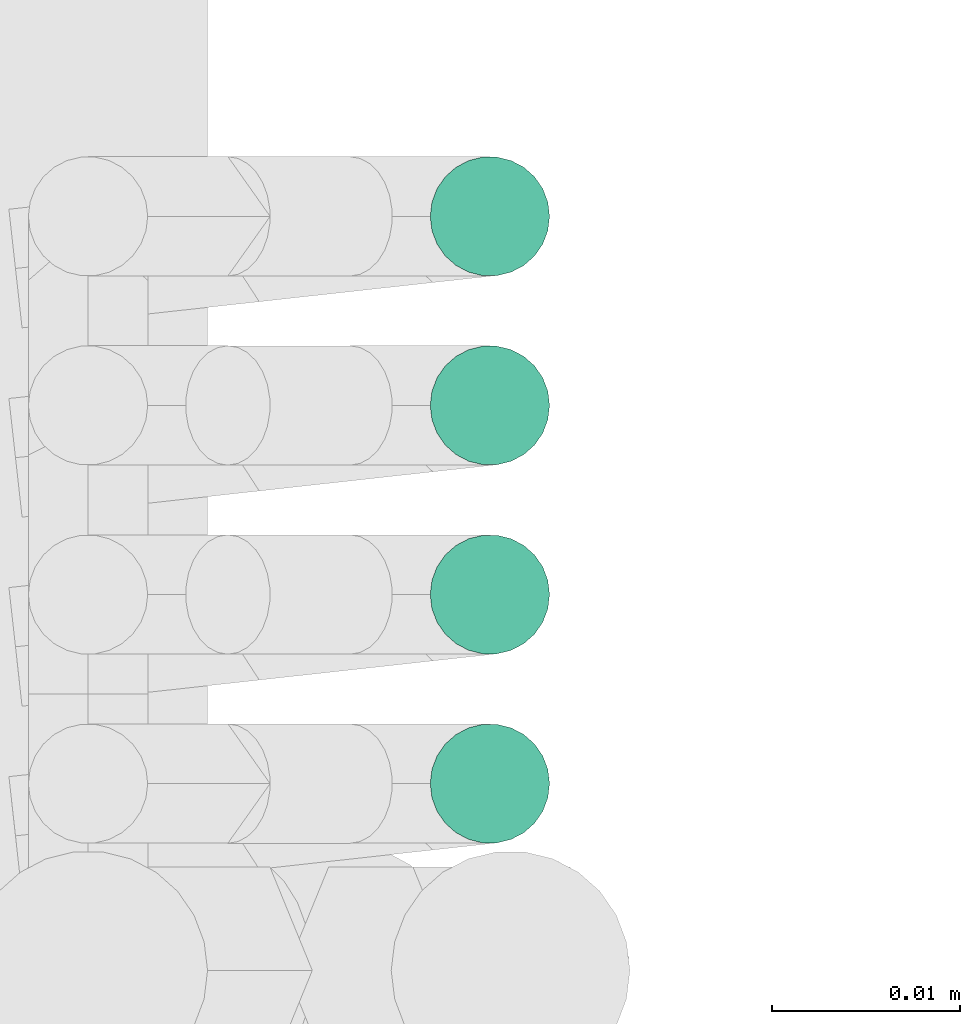
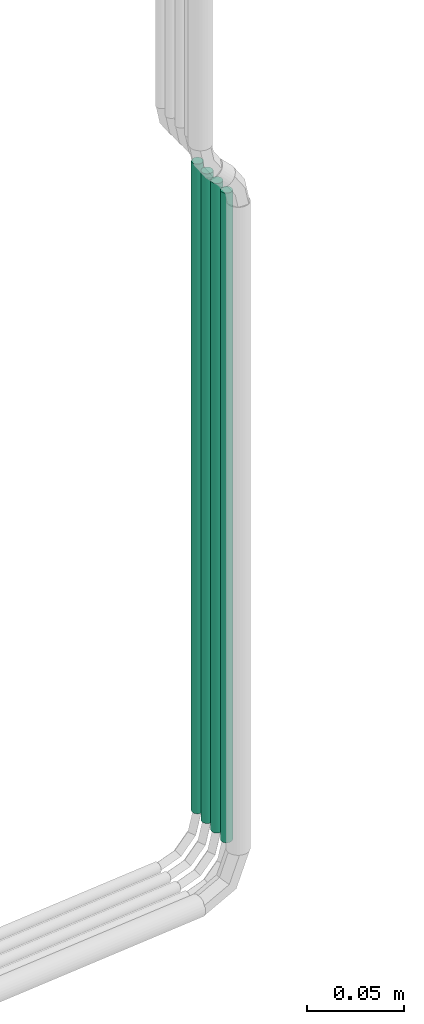
# One storey, part 19 of 45: 4 flow segments.
"""IFC2X3 building model written with IfcOpenShell, lengths in millimetres."""

from ifc_helpers import new_model, entity, si_unit, converted_unit, derived_unit, direction, frame, origin, origin_2d_with_axis, place, context, subcontext, project, spatial, circle, extrude, type_object, element, save


model = new_model("IFC2X3")

# Units and contexts
model_context = context("Model", 3, precision=0.01, world=origin(), true_north=direction((6.12303176911189e-17, 1.0)))
body_context = subcontext(model_context, "Body", "Model", "MODEL_VIEW")
ifc_project = project(units=[si_unit("LENGTHUNIT", "METRE", prefix="MILLI"), si_unit("AREAUNIT", "SQUARE_METRE"), si_unit("VOLUMEUNIT", "CUBIC_METRE"), converted_unit("PLANEANGLEUNIT", "DEGREE", entity("IfcRatioMeasure", 0.0174532925199433), si_unit("PLANEANGLEUNIT", "RADIAN"), dimensions=[0, 0, 0, 0, 0, 0, 0]), si_unit("MASSUNIT", "GRAM", prefix="KILO"), derived_unit("MASSDENSITYUNIT", [(si_unit("MASSUNIT", "GRAM", prefix="KILO"), 1), (si_unit("LENGTHUNIT", "METRE"), -3)]), derived_unit("MOMENTOFINERTIAUNIT", [(si_unit("LENGTHUNIT", "METRE"), 4)]), si_unit("TIMEUNIT", "SECOND"), si_unit("FREQUENCYUNIT", "HERTZ"), si_unit("THERMODYNAMICTEMPERATUREUNIT", "DEGREE_CELSIUS"), derived_unit("THERMALTRANSMITTANCEUNIT", [(si_unit("MASSUNIT", "GRAM", prefix="KILO"), 1), (si_unit("THERMODYNAMICTEMPERATUREUNIT", "KELVIN"), -1), (si_unit("TIMEUNIT", "SECOND"), -3)]), derived_unit("VOLUMETRICFLOWRATEUNIT", [(si_unit("LENGTHUNIT", "METRE"), 3), (si_unit("TIMEUNIT", "SECOND"), -1)]), derived_unit("MASSFLOWRATEUNIT", [(si_unit("MASSUNIT", "GRAM", prefix="KILO"), 1), (si_unit("TIMEUNIT", "SECOND"), -1)]), derived_unit("ROTATIONALFREQUENCYUNIT", [(si_unit("TIMEUNIT", "SECOND"), -1)]), si_unit("ELECTRICCURRENTUNIT", "AMPERE"), si_unit("ELECTRICVOLTAGEUNIT", "VOLT"), si_unit("POWERUNIT", "WATT"), si_unit("FORCEUNIT", "NEWTON", prefix="KILO"), si_unit("ILLUMINANCEUNIT", "LUX"), si_unit("LUMINOUSFLUXUNIT", "LUMEN"), si_unit("LUMINOUSINTENSITYUNIT", "CANDELA"), derived_unit("USERDEFINED", [(si_unit("MASSUNIT", "GRAM", prefix="KILO"), -1), (si_unit("LENGTHUNIT", "METRE"), -2), (si_unit("TIMEUNIT", "SECOND"), 3), (si_unit("LUMINOUSFLUXUNIT", "LUMEN"), 1)]), derived_unit("LINEARVELOCITYUNIT", [(si_unit("LENGTHUNIT", "METRE"), 1), (si_unit("TIMEUNIT", "SECOND"), -1)]), si_unit("PRESSUREUNIT", "PASCAL"), derived_unit("USERDEFINED", [(si_unit("LENGTHUNIT", "METRE"), -2), (si_unit("MASSUNIT", "GRAM", prefix="KILO"), 1), (si_unit("TIMEUNIT", "SECOND"), -2)]), derived_unit("LINEARFORCEUNIT", [(si_unit("MASSUNIT", "GRAM", prefix="KILO"), 1), (si_unit("LENGTHUNIT", "METRE"), 1), (si_unit("TIMEUNIT", "SECOND"), -2), (si_unit("LENGTHUNIT", "METRE"), -1)]), derived_unit("PLANARFORCEUNIT", [(si_unit("MASSUNIT", "GRAM", prefix="KILO"), 1), (si_unit("LENGTHUNIT", "METRE"), 1), (si_unit("TIMEUNIT", "SECOND"), -2), (si_unit("LENGTHUNIT", "METRE"), -2)])], contexts=[model_context])

# Site, building, storey
site_placement = place(None, frame((-24836.06, 8968.75, 0.0)))
site = spatial("IfcSite", under=ifc_project, at=site_placement, CompositionType="ELEMENT")
building_placement = place(site_placement, origin())
building = spatial("IfcBuilding", under=site, at=building_placement, CompositionType="ELEMENT")
storey_placement = place(building_placement, frame((0.0, 0.0, -4200.0)))
storey = spatial("IfcBuildingStorey", under=building, at=storey_placement, CompositionType="ELEMENT", Elevation=-4200.0)

# Flow segments
pipe_segment_type = type_object("IfcPipeSegmentType", PredefinedType="NOTDEFINED")
flow_segment_1_placement = place(storey_placement, frame((80762.36, -7144.01, -374.6)))
element("IfcFlowSegment", 1, at=flow_segment_1_placement, inside=storey, type_object=pipe_segment_type, context=body_context, shape_type="SweptSolid", body=[
    extrude(circle(Radius=3.175, at=origin_2d_with_axis()), frame((4.77, 4.77, 0.0), z_axis=(0.0, 0.0, 1.0), x_axis=(-1.0, 0.0, 0.0)), (0.0, 0.0, 1.0), 409.078975515727),
])
flow_segment_2_placement = place(storey_placement, frame((80762.36, -7133.95, -374.6)))
element("IfcFlowSegment", 2, at=flow_segment_2_placement, inside=storey, type_object=pipe_segment_type, context=body_context, shape_type="SweptSolid", body=[
    extrude(circle(Radius=3.175, at=origin_2d_with_axis()), frame((4.77, 4.77, 0.0), z_axis=(0.0, 0.0, 1.0), x_axis=(-1.0, 0.0, 0.0)), (0.0, 0.0, 1.0), 409.078975515724),
])
flow_segment_3_placement = place(storey_placement, frame((80762.36, -7113.83, -374.6)))
element("IfcFlowSegment", 3, at=flow_segment_3_placement, inside=storey, type_object=pipe_segment_type, context=body_context, shape_type="SweptSolid", body=[
    extrude(circle(Radius=3.175, at=origin_2d_with_axis()), frame((4.77, 4.77, 0.0), z_axis=(0.0, 0.0, 1.0), x_axis=(-1.0, 0.0, 0.0)), (0.0, 0.0, 1.0), 409.078975515563),
])
flow_segment_4_placement = place(storey_placement, frame((80762.36, -7123.89, -374.6)))
element("IfcFlowSegment", 4, at=flow_segment_4_placement, inside=storey, type_object=pipe_segment_type, context=body_context, shape_type="SweptSolid", body=[
    extrude(circle(Radius=3.175, at=origin_2d_with_axis()), frame((4.77, 4.77, 0.0), z_axis=(0.0, 0.0, 1.0), x_axis=(-1.0, 0.0, 0.0)), (0.0, 0.0, 1.0), 409.078975515724),
])

save(model, "model.ifc")
